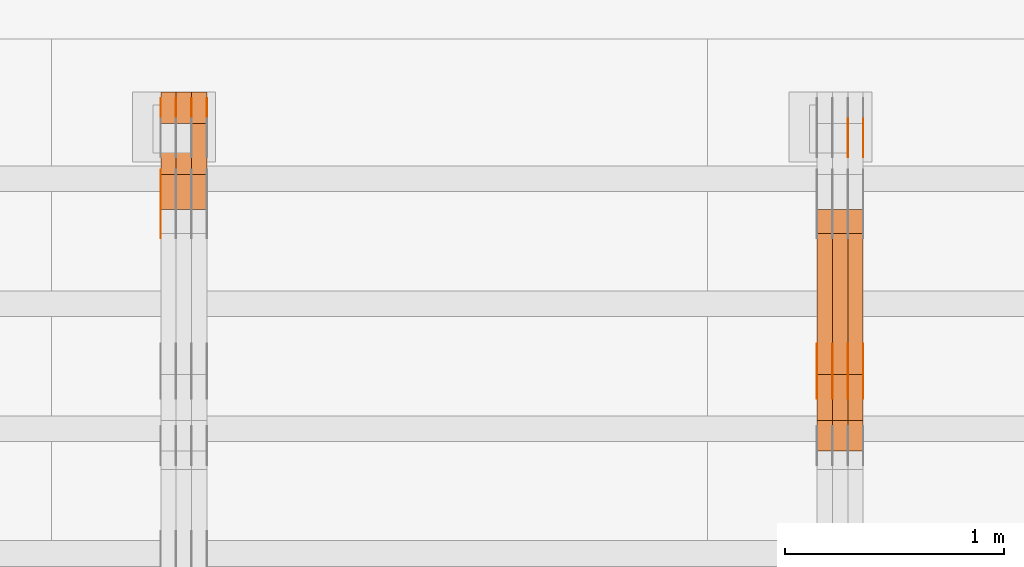
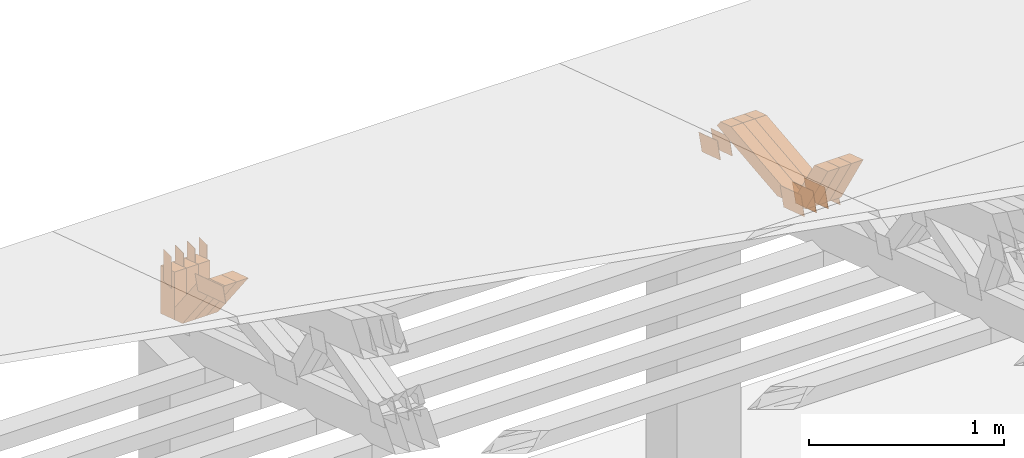
# One storey, part 208 of 385: 28 proxies.
"""IFC2X3 building model written with IfcOpenShell, lengths in millimetres."""

from ifc_helpers import new_model, entity, si_unit, converted_unit, derived_unit, direction, frame, frame_2d, origin, place, context, subcontext, project, spatial, polyline, rectangle, outline, extrude, source, transform, mapped, material, type_object, type_shapes, element, save


model = new_model("IFC2X3")

# Units and contexts
model_context = context("Model", 3, precision=0.01, world=origin(), true_north=direction((6.12303176911189e-17, 1.0)))
body_context = subcontext(model_context, "Body", "Model", "MODEL_VIEW")
ifc_project = project(units=[si_unit("LENGTHUNIT", "METRE", prefix="MILLI"), si_unit("AREAUNIT", "SQUARE_METRE"), si_unit("VOLUMEUNIT", "CUBIC_METRE"), converted_unit("PLANEANGLEUNIT", "DEGREE", entity("IfcRatioMeasure", 0.0174532925199433), si_unit("PLANEANGLEUNIT", "RADIAN"), dimensions=[0, 0, 0, 0, 0, 0, 0]), si_unit("MASSUNIT", "GRAM", prefix="KILO"), derived_unit("MASSDENSITYUNIT", [(si_unit("MASSUNIT", "GRAM", prefix="KILO"), 1), (si_unit("LENGTHUNIT", "METRE"), -3)]), si_unit("TIMEUNIT", "SECOND"), si_unit("FREQUENCYUNIT", "HERTZ"), si_unit("THERMODYNAMICTEMPERATUREUNIT", "DEGREE_CELSIUS"), derived_unit("THERMALTRANSMITTANCEUNIT", [(si_unit("MASSUNIT", "GRAM", prefix="KILO"), 1), (si_unit("THERMODYNAMICTEMPERATUREUNIT", "KELVIN"), -1), (si_unit("TIMEUNIT", "SECOND"), -3)]), derived_unit("VOLUMETRICFLOWRATEUNIT", [(si_unit("LENGTHUNIT", "METRE"), 3), (si_unit("TIMEUNIT", "SECOND"), -1)]), si_unit("ELECTRICCURRENTUNIT", "AMPERE"), si_unit("ELECTRICVOLTAGEUNIT", "VOLT"), si_unit("POWERUNIT", "WATT"), si_unit("FORCEUNIT", "NEWTON", prefix="KILO"), si_unit("ILLUMINANCEUNIT", "LUX"), si_unit("LUMINOUSFLUXUNIT", "LUMEN"), si_unit("LUMINOUSINTENSITYUNIT", "CANDELA"), derived_unit("USERDEFINED", [(si_unit("MASSUNIT", "GRAM", prefix="KILO"), -1), (si_unit("LENGTHUNIT", "METRE"), -2), (si_unit("TIMEUNIT", "SECOND"), 3), (si_unit("LUMINOUSFLUXUNIT", "LUMEN"), 1)]), derived_unit("LINEARVELOCITYUNIT", [(si_unit("LENGTHUNIT", "METRE"), 1), (si_unit("TIMEUNIT", "SECOND"), -1)]), si_unit("PRESSUREUNIT", "PASCAL"), derived_unit("USERDEFINED", [(si_unit("LENGTHUNIT", "METRE"), -2), (si_unit("MASSUNIT", "GRAM", prefix="KILO"), 1), (si_unit("TIMEUNIT", "SECOND"), -2)])], contexts=[model_context])

# Site, building, storey
site_placement = place(None, origin())
site = spatial("IfcSite", under=ifc_project, at=site_placement, CompositionType="ELEMENT")
building_placement = place(site_placement, origin())
building = spatial("IfcBuilding", under=site, at=building_placement, CompositionType="ELEMENT")
storey_placement = place(building_placement, origin())
storey = spatial("IfcBuildingStorey", under=building, at=storey_placement, Name="Default", CompositionType="ELEMENT", Elevation=0.0)

# Proxies
ifc_material_1 = material(Name="IfcSurfaceStyle #206062")
building_element_proxy_type_1 = type_object("IfcBuildingElementProxyType", PredefinedType="NOTDEFINED", material=ifc_material_1)
shared_shape_1 = source(origin(), body_context, "Body", "SweptSolid", [
    extrude(outline(polyline([(-100.000024997547, -54.0000105875654), (100.000088940899, -54.0000105875654), (99.9999100805868, 54.0000105875654), (-99.9999740239394, 54.0000105875654), (-100.000024997547, -54.0000105875654)])), frame((100.000088940899, 54.0000474633838, 0.0), z_axis=(0.0, 0.0, 1.0), x_axis=(-1.0, 0.0, 0.0)), (0.0, 0.0, 1.0), 1.3),
])
type_shapes(building_element_proxy_type_1, [shared_shape_1])
proxy_1_placement = place(building_placement, frame((15386.3, 26390.6212638563, 73.3227520411355), z_axis=(-1.0, 0.0, 0.0), x_axis=(0.0, -0.951056516295124, 0.309016994375039)))
element("IfcBuildingElementProxy", 1, at=proxy_1_placement, inside=storey, type_object=building_element_proxy_type_1, material=ifc_material_1, context=body_context, shape_type="MappedRepresentation", body=[
    mapped(shared_shape_1, transform((0.0, 0.0, 0.0), scale=1.0)),
])
ifc_material_2 = material(Name="IfcSurfaceStyle #206005")
building_element_proxy_type_2 = type_object("IfcBuildingElementProxyType", PredefinedType="NOTDEFINED", material=ifc_material_2)
shared_shape_2 = source(origin(), body_context, "Body", "SweptSolid", [
    extrude(outline(polyline([(-100.000024997547, -54.0000105875654), (100.000088940899, -54.0000105875654), (99.9999100805868, 54.0000105875654), (-99.9999740239394, 54.0000105875654), (-100.000024997547, -54.0000105875654)])), frame((100.000088940899, 54.0000474633838, 0.0), z_axis=(0.0, 0.0, 1.0), x_axis=(-1.0, 0.0, 0.0)), (0.0, 0.0, 1.0), 1.3),
])
type_shapes(building_element_proxy_type_2, [shared_shape_2])
proxy_2_placement = place(building_placement, frame((15315.0, 26390.6212638563, 73.3227520411355), z_axis=(-1.0, 0.0, 0.0), x_axis=(0.0, -0.951056516295124, 0.309016994375039)))
element("IfcBuildingElementProxy", 2, at=proxy_2_placement, inside=storey, type_object=building_element_proxy_type_2, material=ifc_material_2, context=body_context, shape_type="MappedRepresentation", body=[
    mapped(shared_shape_2, transform((0.0, 0.0, 0.0), scale=1.0)),
])
ifc_material_3 = material(Name="IfcSurfaceStyle #205948")
building_element_proxy_type_3 = type_object("IfcBuildingElementProxyType", PredefinedType="NOTDEFINED", material=ifc_material_3)
shared_shape_3 = source(origin(), body_context, "Body", "SweptSolid", [
    extrude(outline(polyline([(-100.000024997547, -54.0000105875654), (100.000088940899, -54.0000105875654), (99.9999100805868, 54.0000105875654), (-99.9999740239394, 54.0000105875654), (-100.000024997547, -54.0000105875654)])), frame((100.000088940899, 54.0000474633838, 0.0), z_axis=(0.0, 0.0, 1.0), x_axis=(-1.0, 0.0, 0.0)), (0.0, 0.0, 1.0), 1.3),
])
type_shapes(building_element_proxy_type_3, [shared_shape_3])
proxy_3_placement = place(building_placement, frame((15316.3, 26390.6212638563, 73.3227520411355), z_axis=(-1.0, 0.0, 0.0), x_axis=(0.0, -0.951056516295124, 0.309016994375039)))
element("IfcBuildingElementProxy", 3, at=proxy_3_placement, inside=storey, type_object=building_element_proxy_type_3, material=ifc_material_3, context=body_context, shape_type="MappedRepresentation", body=[
    mapped(shared_shape_3, transform((0.0, 0.0, 0.0), scale=1.0)),
])
ifc_material_4 = material(Name="IfcSurfaceStyle #194092")
building_element_proxy_type_4 = type_object("IfcBuildingElementProxyType", PredefinedType="NOTDEFINED", material=ifc_material_4)
shared_shape_4 = source(origin(), body_context, "Body", "SweptSolid", [
    extrude(outline(polyline([(-112.50003853564, -60.0000121429077), (112.50002982902, -60.0000121429077), (112.500043250865, 60.0000121429077), (-112.500034544245, 60.0000121429077), (-112.50003853564, -60.0000121429077)])), frame((112.500056021398, 60.0000121429077, 0.0), z_axis=(0.0, 0.0, 1.0), x_axis=(-1.0, 0.0, 0.0)), (0.0, 0.0, 1.0), 1.3),
])
type_shapes(building_element_proxy_type_4, [shared_shape_4])
proxy_4_placement = place(building_placement, frame((15386.3, 25310.2182710494, 430.675738123044), z_axis=(-1.0, 0.0, 0.0), x_axis=(0.0, -0.951056516295124, 0.309016994375039)))
element("IfcBuildingElementProxy", 4, at=proxy_4_placement, inside=storey, type_object=building_element_proxy_type_4, material=ifc_material_4, context=body_context, shape_type="MappedRepresentation", body=[
    mapped(shared_shape_4, transform((0.0, 0.0, 0.0), scale=1.0)),
])
ifc_material_5 = material(Name="IfcSurfaceStyle #194035")
building_element_proxy_type_5 = type_object("IfcBuildingElementProxyType", PredefinedType="NOTDEFINED", material=ifc_material_5)
shared_shape_5 = source(origin(), body_context, "Body", "SweptSolid", [
    extrude(outline(polyline([(-112.50003853564, -60.0000121429077), (112.50002982902, -60.0000121429077), (112.500043250865, 60.0000121429077), (-112.500034544245, 60.0000121429077), (-112.50003853564, -60.0000121429077)])), frame((112.500056021398, 60.0000121429077, 0.0), z_axis=(0.0, 0.0, 1.0), x_axis=(-1.0, 0.0, 0.0)), (0.0, 0.0, 1.0), 1.3),
])
type_shapes(building_element_proxy_type_5, [shared_shape_5])
proxy_5_placement = place(building_placement, frame((15315.0, 25310.2182710494, 430.675738123044), z_axis=(-1.0, 0.0, 0.0), x_axis=(0.0, -0.951056516295124, 0.309016994375039)))
element("IfcBuildingElementProxy", 5, at=proxy_5_placement, inside=storey, type_object=building_element_proxy_type_5, material=ifc_material_5, context=body_context, shape_type="MappedRepresentation", body=[
    mapped(shared_shape_5, transform((0.0, 0.0, 0.0), scale=1.0)),
])
ifc_material_6 = material(Name="IfcSurfaceStyle #193978")
building_element_proxy_type_6 = type_object("IfcBuildingElementProxyType", PredefinedType="NOTDEFINED", material=ifc_material_6)
shared_shape_6 = source(origin(), body_context, "Body", "SweptSolid", [
    extrude(outline(polyline([(-112.50003853564, -60.0000121429077), (112.50002982902, -60.0000121429077), (112.500043250865, 60.0000121429077), (-112.500034544245, 60.0000121429077), (-112.50003853564, -60.0000121429077)])), frame((112.500056021398, 60.0000121429077, 0.0), z_axis=(0.0, 0.0, 1.0), x_axis=(-1.0, 0.0, 0.0)), (0.0, 0.0, 1.0), 1.3),
])
type_shapes(building_element_proxy_type_6, [shared_shape_6])
proxy_6_placement = place(building_placement, frame((15316.3, 25310.2182710494, 430.675738123044), z_axis=(-1.0, 0.0, 0.0), x_axis=(0.0, -0.951056516295124, 0.309016994375039)))
element("IfcBuildingElementProxy", 6, at=proxy_6_placement, inside=storey, type_object=building_element_proxy_type_6, material=ifc_material_6, context=body_context, shape_type="MappedRepresentation", body=[
    mapped(shared_shape_6, transform((0.0, 0.0, 0.0), scale=1.0)),
])
ifc_material_7 = material(Name="IfcSurfaceStyle #193921")
building_element_proxy_type_7 = type_object("IfcBuildingElementProxyType", PredefinedType="NOTDEFINED", material=ifc_material_7)
shared_shape_7 = source(origin(), body_context, "Body", "SweptSolid", [
    extrude(outline(polyline([(-112.50003853564, -60.0000121429077), (112.50002982902, -60.0000121429077), (112.500043250865, 60.0000121429077), (-112.500034544245, 60.0000121429077), (-112.50003853564, -60.0000121429077)])), frame((112.500056021398, 60.0000121429077, 0.0), z_axis=(0.0, 0.0, 1.0), x_axis=(-1.0, 0.0, 0.0)), (0.0, 0.0, 1.0), 1.29999999999998),
])
type_shapes(building_element_proxy_type_7, [shared_shape_7])
proxy_7_placement = place(building_placement, frame((15245.0, 25310.2182710494, 430.675738123044), z_axis=(-1.0, 0.0, 0.0), x_axis=(0.0, -0.951056516295124, 0.309016994375039)))
element("IfcBuildingElementProxy", 7, at=proxy_7_placement, inside=storey, type_object=building_element_proxy_type_7, material=ifc_material_7, context=body_context, shape_type="MappedRepresentation", body=[
    mapped(shared_shape_7, transform((0.0, 0.0, 0.0), scale=1.0)),
])
ifc_material_8 = material(Name="IfcSurfaceStyle #193864")
building_element_proxy_type_8 = type_object("IfcBuildingElementProxyType", PredefinedType="NOTDEFINED", material=ifc_material_8)
shared_shape_8 = source(origin(), body_context, "Body", "SweptSolid", [
    extrude(outline(polyline([(-112.50003853564, -60.0000121429077), (112.50002982902, -60.0000121429077), (112.500043250865, 60.0000121429077), (-112.500034544245, 60.0000121429077), (-112.50003853564, -60.0000121429077)])), frame((112.500056021398, 60.0000121429077, 0.0), z_axis=(0.0, 0.0, 1.0), x_axis=(-1.0, 0.0, 0.0)), (0.0, 0.0, 1.0), 1.29999999999998),
])
type_shapes(building_element_proxy_type_8, [shared_shape_8])
proxy_8_placement = place(building_placement, frame((15246.3, 25310.2182710494, 430.675738123044), z_axis=(-1.0, 0.0, 0.0), x_axis=(0.0, -0.951056516295124, 0.309016994375039)))
element("IfcBuildingElementProxy", 8, at=proxy_8_placement, inside=storey, type_object=building_element_proxy_type_8, material=ifc_material_8, context=body_context, shape_type="MappedRepresentation", body=[
    mapped(shared_shape_8, transform((0.0, 0.0, 0.0), scale=1.0)),
])
ifc_material_9 = material(Name="IfcSurfaceStyle #193807")
building_element_proxy_type_9 = type_object("IfcBuildingElementProxyType", PredefinedType="NOTDEFINED", material=ifc_material_9)
shared_shape_9 = source(origin(), body_context, "Body", "SweptSolid", [
    extrude(outline(polyline([(-112.50003853564, -60.0000121429077), (112.50002982902, -60.0000121429077), (112.500043250865, 60.0000121429077), (-112.500034544245, 60.0000121429077), (-112.50003853564, -60.0000121429077)])), frame((112.500056021398, 60.0000121429077, 0.0), z_axis=(0.0, 0.0, 1.0), x_axis=(-1.0, 0.0, 0.0)), (0.0, 0.0, 1.0), 1.29999999999999),
])
type_shapes(building_element_proxy_type_9, [shared_shape_9])
proxy_9_placement = place(building_placement, frame((15175.0, 25310.2182710494, 430.675738123044), z_axis=(-1.0, 0.0, 0.0), x_axis=(0.0, -0.951056516295124, 0.309016994375039)))
element("IfcBuildingElementProxy", 9, at=proxy_9_placement, inside=storey, type_object=building_element_proxy_type_9, material=ifc_material_9, context=body_context, shape_type="MappedRepresentation", body=[
    mapped(shared_shape_9, transform((0.0, 0.0, 0.0), scale=1.0)),
])
ifc_material_10 = material(Name="IfcSurfaceStyle #182050")
building_element_proxy_type_10 = type_object("IfcBuildingElementProxyType", Name="T1-W31 182048", PredefinedType="NOTDEFINED", material=ifc_material_10)
shared_shape_10 = source(origin(), body_context, "Body", "SweptSolid", [
    extrude(outline(polyline([(-201.245318299844, -47.5000121670808), (204.413774229459, -47.5000121670808), (182.034306640891, 5.35692244583164e-05), (126.70380769348, 47.4999853824686), (-311.906570263987, 47.4999853824686), (-201.245318299844, -47.5000121670808)])), frame((204.413774229459, 47.5002684334588, 0.0), z_axis=(0.0, 0.0, 1.0), x_axis=(-1.0, 0.0, 0.0)), (0.0, 0.0, 1.0), 70.0),
])
type_shapes(building_element_proxy_type_10, [shared_shape_10])
proxy_10_placement = place(building_placement, frame((15385.0, 25127.5652647985, 487.27008059185), z_axis=(-1.0, 0.0, 0.0), x_axis=(0.0, -0.520333970303023, 0.853962855953755)))
element("IfcBuildingElementProxy", 10, at=proxy_10_placement, inside=storey, type_object=building_element_proxy_type_10, material=ifc_material_10, Name="T1-W31", context=body_context, shape_type="MappedRepresentation", body=[
    mapped(shared_shape_10, transform((0.0, 0.0, 0.0), scale=1.0)),
])
ifc_material_11 = material(Name="IfcSurfaceStyle #181984")
building_element_proxy_type_11 = type_object("IfcBuildingElementProxyType", Name="T1-W31 181982", PredefinedType="NOTDEFINED", material=ifc_material_11)
shared_shape_11 = source(origin(), body_context, "Body", "SweptSolid", [
    extrude(outline(polyline([(-201.245318299844, -47.5000121670808), (204.413774229459, -47.5000121670808), (182.034306640891, 5.35692244583164e-05), (126.70380769348, 47.4999853824686), (-311.906570263987, 47.4999853824686), (-201.245318299844, -47.5000121670808)])), frame((204.413774229459, 47.5002684334588, 0.0), z_axis=(0.0, 0.0, 1.0), x_axis=(-1.0, 0.0, 0.0)), (0.0, 0.0, 1.0), 70.0),
])
type_shapes(building_element_proxy_type_11, [shared_shape_11])
proxy_11_placement = place(building_placement, frame((15315.0, 25127.5652647985, 487.27008059185), z_axis=(-1.0, 0.0, 0.0), x_axis=(0.0, -0.520333970303023, 0.853962855953755)))
element("IfcBuildingElementProxy", 11, at=proxy_11_placement, inside=storey, type_object=building_element_proxy_type_11, material=ifc_material_11, Name="T1-W31", context=body_context, shape_type="MappedRepresentation", body=[
    mapped(shared_shape_11, transform((0.0, 0.0, 0.0), scale=1.0)),
])
ifc_material_12 = material(Name="IfcSurfaceStyle #181918")
building_element_proxy_type_12 = type_object("IfcBuildingElementProxyType", Name="T1-W31 181916", PredefinedType="NOTDEFINED", material=ifc_material_12)
shared_shape_12 = source(origin(), body_context, "Body", "SweptSolid", [
    extrude(outline(polyline([(-201.245318299844, -47.5000121670808), (204.413774229459, -47.5000121670808), (182.034306640891, 5.35692244583164e-05), (126.70380769348, 47.4999853824686), (-311.906570263987, 47.4999853824686), (-201.245318299844, -47.5000121670808)])), frame((204.413774229459, 47.5002684334588, 0.0), z_axis=(0.0, 0.0, 1.0), x_axis=(-1.0, 0.0, 0.0)), (0.0, 0.0, 1.0), 70.0),
])
type_shapes(building_element_proxy_type_12, [shared_shape_12])
proxy_12_placement = place(building_placement, frame((15245.0, 25127.5652647985, 487.27008059185), z_axis=(-1.0, 0.0, 0.0), x_axis=(0.0, -0.520333970303023, 0.853962855953755)))
element("IfcBuildingElementProxy", 12, at=proxy_12_placement, inside=storey, type_object=building_element_proxy_type_12, material=ifc_material_12, Name="T1-W31", context=body_context, shape_type="MappedRepresentation", body=[
    mapped(shared_shape_12, transform((0.0, 0.0, 0.0), scale=1.0)),
])
ifc_material_13 = material(Name="IfcSurfaceStyle #181654")
building_element_proxy_type_13 = type_object("IfcBuildingElementProxyType", Name="T1-W4 181652", PredefinedType="NOTDEFINED", material=ifc_material_13)
shared_shape_13 = source(origin(), body_context, "Body", "SweptSolid", [
    extrude(outline(polyline([(-510.077325435179, -47.4999981284922), (188.854793418912, -47.4999981284922), (294.906688207675, 1.67015383116809e-05), (324.289382923648, 47.499989777723), (-297.973539115057, 47.4999897777231), (-510.077325435179, -47.4999981284922)])), frame((324.289382923648, 47.5000278316275, 0.0), z_axis=(0.0, 0.0, 1.0), x_axis=(-1.0, 0.0, 0.0)), (0.0, 0.0, 1.0), 70.0),
])
type_shapes(building_element_proxy_type_13, [shared_shape_13])
proxy_13_placement = place(building_placement, frame((15385.0, 25996.2241251556, 525.69905884318), z_axis=(-1.0, 0.0, 0.0), x_axis=(0.0, -0.994287125203057, -0.106738524701444)))
element("IfcBuildingElementProxy", 13, at=proxy_13_placement, inside=storey, type_object=building_element_proxy_type_13, material=ifc_material_13, Name="T1-W4", context=body_context, shape_type="MappedRepresentation", body=[
    mapped(shared_shape_13, transform((0.0, 0.0, 0.0), scale=1.0)),
])
ifc_material_14 = material(Name="IfcSurfaceStyle #181588")
building_element_proxy_type_14 = type_object("IfcBuildingElementProxyType", Name="T1-W4 181586", PredefinedType="NOTDEFINED", material=ifc_material_14)
shared_shape_14 = source(origin(), body_context, "Body", "SweptSolid", [
    extrude(outline(polyline([(-510.077325435179, -47.4999981284922), (188.854793418912, -47.4999981284922), (294.906688207675, 1.67015383116809e-05), (324.289382923648, 47.499989777723), (-297.973539115057, 47.4999897777231), (-510.077325435179, -47.4999981284922)])), frame((324.289382923648, 47.5000278316275, 0.0), z_axis=(0.0, 0.0, 1.0), x_axis=(-1.0, 0.0, 0.0)), (0.0, 0.0, 1.0), 70.0),
])
type_shapes(building_element_proxy_type_14, [shared_shape_14])
proxy_14_placement = place(building_placement, frame((15315.0, 25996.2241251556, 525.69905884318), z_axis=(-1.0, 0.0, 0.0), x_axis=(0.0, -0.994287125203057, -0.106738524701444)))
element("IfcBuildingElementProxy", 14, at=proxy_14_placement, inside=storey, type_object=building_element_proxy_type_14, material=ifc_material_14, Name="T1-W4", context=body_context, shape_type="MappedRepresentation", body=[
    mapped(shared_shape_14, transform((0.0, 0.0, 0.0), scale=1.0)),
])
ifc_material_15 = material(Name="IfcSurfaceStyle #181522")
building_element_proxy_type_15 = type_object("IfcBuildingElementProxyType", Name="T1-W4 181520", PredefinedType="NOTDEFINED", material=ifc_material_15)
shared_shape_15 = source(origin(), body_context, "Body", "SweptSolid", [
    extrude(outline(polyline([(-510.077325435179, -47.4999981284922), (188.854793418912, -47.4999981284922), (294.906688207675, 1.67015383116809e-05), (324.289382923648, 47.499989777723), (-297.973539115057, 47.4999897777231), (-510.077325435179, -47.4999981284922)])), frame((324.289382923648, 47.5000278316275, 0.0), z_axis=(0.0, 0.0, 1.0), x_axis=(-1.0, 0.0, 0.0)), (0.0, 0.0, 1.0), 70.0),
])
type_shapes(building_element_proxy_type_15, [shared_shape_15])
proxy_15_placement = place(building_placement, frame((15245.0, 25996.2241251556, 525.69905884318), z_axis=(-1.0, 0.0, 0.0), x_axis=(0.0, -0.994287125203057, -0.106738524701444)))
element("IfcBuildingElementProxy", 15, at=proxy_15_placement, inside=storey, type_object=building_element_proxy_type_15, material=ifc_material_15, Name="T1-W4", context=body_context, shape_type="MappedRepresentation", body=[
    mapped(shared_shape_15, transform((0.0, 0.0, 0.0), scale=1.0)),
])
ifc_material_16 = material(Name="IfcSurfaceStyle #158691")
building_element_proxy_type_16 = type_object("IfcBuildingElementProxyType", PredefinedType="NOTDEFINED", material=ifc_material_16)
shared_shape_16 = source(origin(), body_context, "Body", "SweptSolid", [
    extrude(outline(polyline([(-149.999901061401, -48.0000057587028), (150.000035297123, -48.0000057587028), (149.999910491851, 48.0000057587028), (-150.000044727574, 48.0000057587028), (-149.999901061401, -48.0000057587028)])), frame((150.000035297123, 48.0000632585775, 0.0), z_axis=(0.0, 0.0, 1.0), x_axis=(-1.0, 0.0, 0.0)), (0.0, 0.0, 1.0), 1.29999999999998),
])
type_shapes(building_element_proxy_type_16, [shared_shape_16])
proxy_16_placement = place(building_placement, frame((12175.0, 26115.0176968219, 469.58296924555), z_axis=(-1.0, 0.0, 0.0), x_axis=(0.0, -0.951056516295154, 0.309016994374948)))
element("IfcBuildingElementProxy", 16, at=proxy_16_placement, inside=storey, type_object=building_element_proxy_type_16, material=ifc_material_16, context=body_context, shape_type="MappedRepresentation", body=[
    mapped(shared_shape_16, transform((0.0, 0.0, 0.0), scale=1.0)),
])
ifc_material_17 = material(Name="IfcSurfaceStyle #158634")
building_element_proxy_type_17 = type_object("IfcBuildingElementProxyType", PredefinedType="NOTDEFINED", material=ifc_material_17)
shared_shape_17 = source(origin(), body_context, "Body", "SweptSolid", [
    extrude(rectangle(XDim=200.0, YDim=84.0000000000005, at=frame_2d((-2.1316282072803e-14, 1.06581410364015e-14), x_axis=(1.0, 0.0))), frame((100.0, 42.0, 0.0), z_axis=(0.0, 0.0, 1.0), x_axis=(-1.0, 0.0, 0.0)), (0.0, 0.0, 1.0), 1.3),
])
type_shapes(building_element_proxy_type_17, [shared_shape_17])
proxy_17_placement = place(building_placement, frame((12386.3, 26469.5000000002, 518.521545410156), z_axis=(-1.0, 0.0, 0.0), x_axis=(0.0, 0.0, -1.0)))
element("IfcBuildingElementProxy", 17, at=proxy_17_placement, inside=storey, type_object=building_element_proxy_type_17, material=ifc_material_17, context=body_context, shape_type="MappedRepresentation", body=[
    mapped(shared_shape_17, transform((0.0, 0.0, 0.0), scale=1.0)),
])
ifc_material_18 = material(Name="IfcSurfaceStyle #158577")
building_element_proxy_type_18 = type_object("IfcBuildingElementProxyType", PredefinedType="NOTDEFINED", material=ifc_material_18)
shared_shape_18 = source(origin(), body_context, "Body", "SweptSolid", [
    extrude(rectangle(XDim=200.0, YDim=84.0000000000005, at=frame_2d((-2.1316282072803e-14, 1.06581410364015e-14), x_axis=(1.0, 0.0))), frame((100.0, 42.0, 0.0), z_axis=(0.0, 0.0, 1.0), x_axis=(-1.0, 0.0, 0.0)), (0.0, 0.0, 1.0), 1.3),
])
type_shapes(building_element_proxy_type_18, [shared_shape_18])
proxy_18_placement = place(building_placement, frame((12315.0, 26469.5000000002, 518.521545410156), z_axis=(-1.0, 0.0, 0.0), x_axis=(0.0, 0.0, -1.0)))
element("IfcBuildingElementProxy", 18, at=proxy_18_placement, inside=storey, type_object=building_element_proxy_type_18, material=ifc_material_18, context=body_context, shape_type="MappedRepresentation", body=[
    mapped(shared_shape_18, transform((0.0, 0.0, 0.0), scale=1.0)),
])
ifc_material_19 = material(Name="IfcSurfaceStyle #158520")
building_element_proxy_type_19 = type_object("IfcBuildingElementProxyType", PredefinedType="NOTDEFINED", material=ifc_material_19)
shared_shape_19 = source(origin(), body_context, "Body", "SweptSolid", [
    extrude(rectangle(XDim=200.0, YDim=84.0000000000005, at=frame_2d((-2.1316282072803e-14, 1.06581410364015e-14), x_axis=(1.0, 0.0))), frame((100.0, 42.0, 0.0), z_axis=(0.0, 0.0, 1.0), x_axis=(-1.0, 0.0, 0.0)), (0.0, 0.0, 1.0), 1.3),
])
type_shapes(building_element_proxy_type_19, [shared_shape_19])
proxy_19_placement = place(building_placement, frame((12316.3, 26469.5000000002, 518.521545410156), z_axis=(-1.0, 0.0, 0.0), x_axis=(0.0, 0.0, -1.0)))
element("IfcBuildingElementProxy", 19, at=proxy_19_placement, inside=storey, type_object=building_element_proxy_type_19, material=ifc_material_19, context=body_context, shape_type="MappedRepresentation", body=[
    mapped(shared_shape_19, transform((0.0, 0.0, 0.0), scale=1.0)),
])
ifc_material_20 = material(Name="IfcSurfaceStyle #158463")
building_element_proxy_type_20 = type_object("IfcBuildingElementProxyType", PredefinedType="NOTDEFINED", material=ifc_material_20)
shared_shape_20 = source(origin(), body_context, "Body", "SweptSolid", [
    extrude(rectangle(XDim=200.0, YDim=84.0000000000005, at=frame_2d((-2.1316282072803e-14, 1.06581410364015e-14), x_axis=(1.0, 0.0))), frame((100.0, 42.0, 0.0), z_axis=(0.0, 0.0, 1.0), x_axis=(-1.0, 0.0, 0.0)), (0.0, 0.0, 1.0), 1.29999999999998),
])
type_shapes(building_element_proxy_type_20, [shared_shape_20])
proxy_20_placement = place(building_placement, frame((12245.0, 26469.5000000002, 518.521545410156), z_axis=(-1.0, 0.0, 0.0), x_axis=(0.0, 0.0, -1.0)))
element("IfcBuildingElementProxy", 20, at=proxy_20_placement, inside=storey, type_object=building_element_proxy_type_20, material=ifc_material_20, context=body_context, shape_type="MappedRepresentation", body=[
    mapped(shared_shape_20, transform((0.0, 0.0, 0.0), scale=1.0)),
])
ifc_material_21 = material(Name="IfcSurfaceStyle #158406")
building_element_proxy_type_21 = type_object("IfcBuildingElementProxyType", PredefinedType="NOTDEFINED", material=ifc_material_21)
shared_shape_21 = source(origin(), body_context, "Body", "SweptSolid", [
    extrude(rectangle(XDim=200.0, YDim=84.0000000000005, at=frame_2d((-2.1316282072803e-14, 1.06581410364015e-14), x_axis=(1.0, 0.0))), frame((100.0, 42.0, 0.0), z_axis=(0.0, 0.0, 1.0), x_axis=(-1.0, 0.0, 0.0)), (0.0, 0.0, 1.0), 1.29999999999998),
])
type_shapes(building_element_proxy_type_21, [shared_shape_21])
proxy_21_placement = place(building_placement, frame((12246.3, 26469.5000000002, 518.521545410156), z_axis=(-1.0, 0.0, 0.0), x_axis=(0.0, 0.0, -1.0)))
element("IfcBuildingElementProxy", 21, at=proxy_21_placement, inside=storey, type_object=building_element_proxy_type_21, material=ifc_material_21, context=body_context, shape_type="MappedRepresentation", body=[
    mapped(shared_shape_21, transform((0.0, 0.0, 0.0), scale=1.0)),
])
ifc_material_22 = material(Name="IfcSurfaceStyle #158349")
building_element_proxy_type_22 = type_object("IfcBuildingElementProxyType", PredefinedType="NOTDEFINED", material=ifc_material_22)
shared_shape_22 = source(origin(), body_context, "Body", "SweptSolid", [
    extrude(rectangle(XDim=200.0, YDim=84.0000000000005, at=frame_2d((-2.1316282072803e-14, 1.06581410364015e-14), x_axis=(1.0, 0.0))), frame((100.0, 42.0, 0.0), z_axis=(0.0, 0.0, 1.0), x_axis=(-1.0, 0.0, 0.0)), (0.0, 0.0, 1.0), 1.29999999999999),
])
type_shapes(building_element_proxy_type_22, [shared_shape_22])
proxy_22_placement = place(building_placement, frame((12175.0, 26469.5000000002, 518.521545410156), z_axis=(-1.0, 0.0, 0.0), x_axis=(0.0, 0.0, -1.0)))
element("IfcBuildingElementProxy", 22, at=proxy_22_placement, inside=storey, type_object=building_element_proxy_type_22, material=ifc_material_22, context=body_context, shape_type="MappedRepresentation", body=[
    mapped(shared_shape_22, transform((0.0, 0.0, 0.0), scale=1.0)),
])
ifc_material_23 = material(Name="IfcSurfaceStyle #146826")
building_element_proxy_type_23 = type_object("IfcBuildingElementProxyType", Name="T1-W21 146824", PredefinedType="NOTDEFINED", material=ifc_material_23)
shared_shape_23 = source(origin(), body_context, "Body", "SweptSolid", [
    extrude(outline(polyline([(-209.199362597501, -47.5000308982766), (168.813164734153, -47.5000308982766), (229.900717355638, -2.18385470334148e-05), (159.828709317766, 47.5000418175501), (-349.343228810055, 47.5000418175502), (-209.199362597501, -47.5000308982766)])), frame((229.900720156071, 47.5000418175501, 0.0), z_axis=(0.0, 0.0, 1.0), x_axis=(-1.0, 0.0, 0.0)), (0.0, 0.0, 1.0), 70.0),
])
type_shapes(building_element_proxy_type_23, [shared_shape_23])
proxy_23_placement = place(building_placement, frame((12385.0, 26317.5019908272, 112.518372832984), z_axis=(-1.0, 0.0, 0.0), x_axis=(0.0, -0.613839629272042, 0.789430750310097)))
element("IfcBuildingElementProxy", 23, at=proxy_23_placement, inside=storey, type_object=building_element_proxy_type_23, material=ifc_material_23, Name="T1-W21", context=body_context, shape_type="MappedRepresentation", body=[
    mapped(shared_shape_23, transform((0.0, 0.0, 0.0), scale=1.0)),
])
ifc_material_24 = material(Name="IfcSurfaceStyle #146760")
building_element_proxy_type_24 = type_object("IfcBuildingElementProxyType", Name="T1-W21 146758", PredefinedType="NOTDEFINED", material=ifc_material_24)
shared_shape_24 = source(origin(), body_context, "Body", "SweptSolid", [
    extrude(outline(polyline([(-209.199362597501, -47.5000308982766), (168.813164734153, -47.5000308982766), (229.900717355638, -2.18385470334148e-05), (159.828709317766, 47.5000418175501), (-349.343228810055, 47.5000418175502), (-209.199362597501, -47.5000308982766)])), frame((229.900720156071, 47.5000418175501, 0.0), z_axis=(0.0, 0.0, 1.0), x_axis=(-1.0, 0.0, 0.0)), (0.0, 0.0, 1.0), 70.0),
])
type_shapes(building_element_proxy_type_24, [shared_shape_24])
proxy_24_placement = place(building_placement, frame((12315.0, 26317.5019908272, 112.518372832984), z_axis=(-1.0, 0.0, 0.0), x_axis=(0.0, -0.613839629272042, 0.789430750310097)))
element("IfcBuildingElementProxy", 24, at=proxy_24_placement, inside=storey, type_object=building_element_proxy_type_24, material=ifc_material_24, Name="T1-W21", context=body_context, shape_type="MappedRepresentation", body=[
    mapped(shared_shape_24, transform((0.0, 0.0, 0.0), scale=1.0)),
])
ifc_material_25 = material(Name="IfcSurfaceStyle #146694")
building_element_proxy_type_25 = type_object("IfcBuildingElementProxyType", Name="T1-W21 146692", PredefinedType="NOTDEFINED", material=ifc_material_25)
shared_shape_25 = source(origin(), body_context, "Body", "SweptSolid", [
    extrude(outline(polyline([(-209.199362597501, -47.5000308982766), (168.813164734153, -47.5000308982766), (229.900717355638, -2.18385470334148e-05), (159.828709317766, 47.5000418175501), (-349.343228810055, 47.5000418175502), (-209.199362597501, -47.5000308982766)])), frame((229.900720156071, 47.5000418175501, 0.0), z_axis=(0.0, 0.0, 1.0), x_axis=(-1.0, 0.0, 0.0)), (0.0, 0.0, 1.0), 70.0),
])
type_shapes(building_element_proxy_type_25, [shared_shape_25])
proxy_25_placement = place(building_placement, frame((12245.0, 26317.5019908272, 112.518372832984), z_axis=(-1.0, 0.0, 0.0), x_axis=(0.0, -0.613839629272042, 0.789430750310097)))
element("IfcBuildingElementProxy", 25, at=proxy_25_placement, inside=storey, type_object=building_element_proxy_type_25, material=ifc_material_25, Name="T1-W21", context=body_context, shape_type="MappedRepresentation", body=[
    mapped(shared_shape_25, transform((0.0, 0.0, 0.0), scale=1.0)),
])
ifc_material_26 = material(Name="IfcSurfaceStyle #146259")
building_element_proxy_type_26 = type_object("IfcBuildingElementProxyType", Name="T1-E2 146257", PredefinedType="NOTDEFINED", material=ifc_material_26)
shared_shape_26 = source(origin(), body_context, "Body", "SweptSolid", [
    extrude(outline(polyline([(-126.644535064697, -72.4999999999998), (173.757884979248, -72.4999999999998), (126.644542694092, 72.4999999999998), (-173.757892608642, 72.4999999999998), (-126.644535064697, -72.4999999999998)])), frame((173.757890653796, 72.5000000000002, 0.0), z_axis=(0.0, 0.0, 1.0), x_axis=(-1.0, 0.0, 0.0)), (0.0, 0.0, 1.0), 70.0),
])
type_shapes(building_element_proxy_type_26, [shared_shape_26])
proxy_26_placement = place(building_placement, frame((12385.0, 26500.0, 442.078222227283), z_axis=(-1.0, 0.0, 0.0), x_axis=(0.0, 0.0, -1.0)))
element("IfcBuildingElementProxy", 26, at=proxy_26_placement, inside=storey, type_object=building_element_proxy_type_26, material=ifc_material_26, Name="T1-E2", context=body_context, shape_type="MappedRepresentation", body=[
    mapped(shared_shape_26, transform((0.0, 0.0, 0.0), scale=1.0)),
])
ifc_material_27 = material(Name="IfcSurfaceStyle #146202")
building_element_proxy_type_27 = type_object("IfcBuildingElementProxyType", Name="T1-E2 146200", PredefinedType="NOTDEFINED", material=ifc_material_27)
shared_shape_27 = source(origin(), body_context, "Body", "SweptSolid", [
    extrude(outline(polyline([(-126.644535064697, -72.4999999999998), (173.757884979248, -72.4999999999998), (126.644542694092, 72.4999999999998), (-173.757892608642, 72.4999999999998), (-126.644535064697, -72.4999999999998)])), frame((173.757890653796, 72.5000000000002, 0.0), z_axis=(0.0, 0.0, 1.0), x_axis=(-1.0, 0.0, 0.0)), (0.0, 0.0, 1.0), 70.0),
])
type_shapes(building_element_proxy_type_27, [shared_shape_27])
proxy_27_placement = place(building_placement, frame((12315.0, 26500.0, 442.078222227283), z_axis=(-1.0, 0.0, 0.0), x_axis=(0.0, 0.0, -1.0)))
element("IfcBuildingElementProxy", 27, at=proxy_27_placement, inside=storey, type_object=building_element_proxy_type_27, material=ifc_material_27, Name="T1-E2", context=body_context, shape_type="MappedRepresentation", body=[
    mapped(shared_shape_27, transform((0.0, 0.0, 0.0), scale=1.0)),
])
ifc_material_28 = material(Name="IfcSurfaceStyle #146145")
building_element_proxy_type_28 = type_object("IfcBuildingElementProxyType", Name="T1-E2 146143", PredefinedType="NOTDEFINED", material=ifc_material_28)
shared_shape_28 = source(origin(), body_context, "Body", "SweptSolid", [
    extrude(outline(polyline([(-126.644535064697, -72.4999999999998), (173.757884979248, -72.4999999999998), (126.644542694092, 72.4999999999998), (-173.757892608642, 72.4999999999998), (-126.644535064697, -72.4999999999998)])), frame((173.757890653796, 72.5000000000002, 0.0), z_axis=(0.0, 0.0, 1.0), x_axis=(-1.0, 0.0, 0.0)), (0.0, 0.0, 1.0), 70.0),
])
type_shapes(building_element_proxy_type_28, [shared_shape_28])
proxy_28_placement = place(building_placement, frame((12245.0, 26500.0, 442.078222227283), z_axis=(-1.0, 0.0, 0.0), x_axis=(0.0, 0.0, -1.0)))
element("IfcBuildingElementProxy", 28, at=proxy_28_placement, inside=storey, type_object=building_element_proxy_type_28, material=ifc_material_28, Name="T1-E2", context=body_context, shape_type="MappedRepresentation", body=[
    mapped(shared_shape_28, transform((0.0, 0.0, 0.0), scale=1.0)),
])

save(model, "model.ifc")
